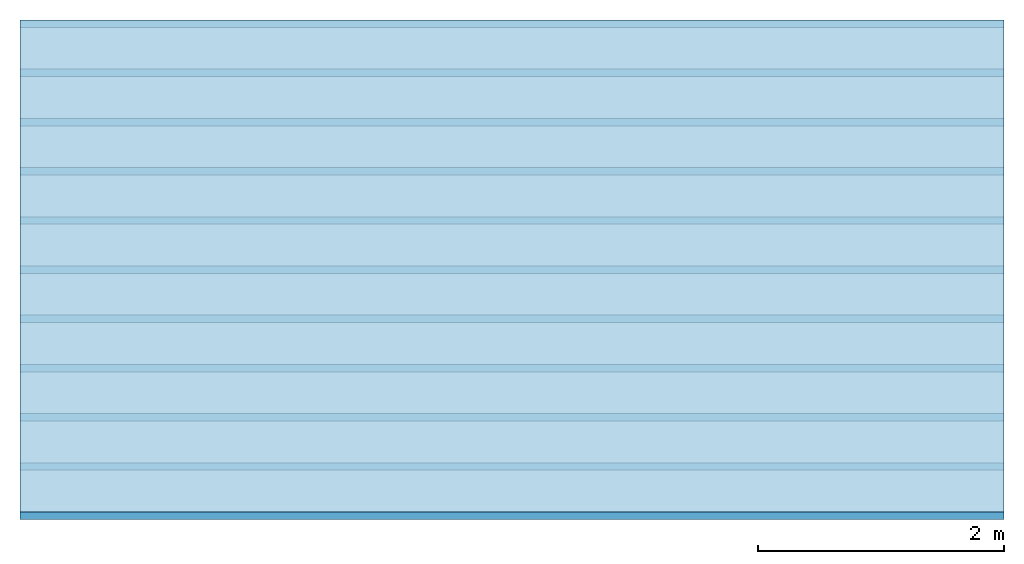
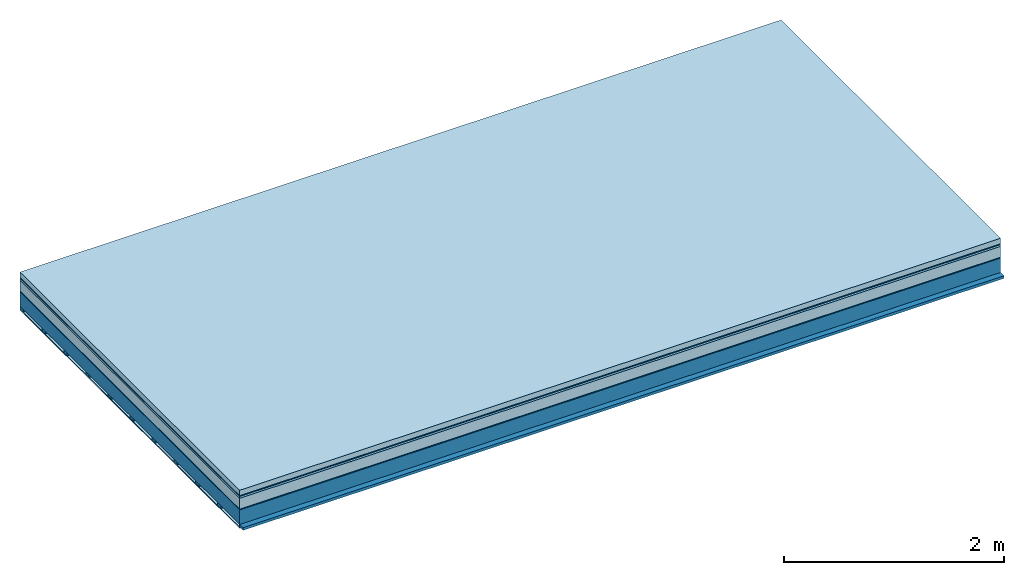
# One storey: 7 plates, 2 members, 1 element without a shape of its own.
"""IFC4 building model written with IfcOpenShell, lengths in metres."""

from ifc_helpers import new_model, si_unit, derived_unit, direction, frame, frame_2d, origin, origin_with_axes, place, context, project, spatial, rectangle, extrude, material, layer, layer_set, type_object, element, aggregate, save


model = new_model("IFC4")

# Units and contexts
plan_context = context("Plan", 3, precision=1e-05, world=origin(), true_north=direction((0.0, 1.0)))
model_context = context("Model", 3, precision=1e-05, world=origin(), true_north=direction((0.0, 1.0)))
ifc_project = project(units=[si_unit("LENGTHUNIT", "METRE"), derived_unit("SOUNDPRESSUREUNIT", [(si_unit("PRESSUREUNIT", "PASCAL", prefix="MICRO"), 0)]), si_unit("ENERGYUNIT", "JOULE", prefix="MEGA"), si_unit("MASSUNIT", "GRAM", prefix="KILO"), derived_unit("THERMALTRANSMITTANCEUNIT", [(si_unit("POWERUNIT", "WATT"), 1), (si_unit("AREAUNIT", "SQUARE_METRE"), -1), (si_unit("THERMODYNAMICTEMPERATUREUNIT", "KELVIN"), -1)]), derived_unit("AREADENSITYUNIT", [(si_unit("MASSUNIT", "GRAM", prefix="KILO"), 1), (si_unit("AREAUNIT", "SQUARE_METRE"), -1)]), derived_unit("USERDEFINED", [(si_unit("ENERGYUNIT", "JOULE", prefix="MEGA"), 1), (si_unit("AREAUNIT", "SQUARE_METRE"), -1)])], contexts=[plan_context, model_context])

# Site, building, storey
site = spatial("IfcSite", under=ifc_project)
building_placement = place(None, origin())
building = spatial("IfcBuilding", under=site, at=building_placement)
storey_placement = place(building_placement, origin())
storey = spatial("IfcBuildingStorey", under=building, at=storey_placement)

# Slab, members, plates
ifc_material_1 = material(Name="clay", Category="02.004")
ifc_layer_1 = layer(ifc_material_1, 0.06, Name="Use and protection layer 2")
ifc_material_2 = material(Name="Protective layer", Category="09.007")
ifc_layer_2 = layer(ifc_material_2, 0.01, Name="Use and protection layer 1")
ifc_material_3 = material(Name="Bituminous", Category="09.003")
ifc_layer_3 = layer(ifc_material_3, 0.02, Name="Seal")
ifc_material_4 = material(Name="Mineral wool", Category="10.008")
ifc_layer_4 = layer(ifc_material_4, 0.12, Name="Exterior insulation layer 1")
ifc_material_5 = material(Name="Vapor-permeable barrier", Category="09.006")
ifc_layer_5 = layer(ifc_material_5, 0.01, Name="layer / temporary roof")
ifc_material_6 = material(Name="no composite action")
ifc_layer_6 = layer(ifc_material_6, 0.0, Name="Bond")
ifc_layer_7 = layer(None, 0.16, Name="Support")
ifc_material_7 = material(Name="of the art")
ifc_layer_8 = layer(ifc_material_7, 0.0, Name="Bond")
ifc_layer_9 = layer(None, 0.03, Name="Battens / profiles")
ifc_material_8 = material(Name="Plasterboard type A", Category="03.008")
ifc_layer_10 = layer(ifc_material_8, 0.0125, Name="Covering below 1st layer")
ifc_material_9 = material(Category="04.001")
ifc_layer_11 = layer(ifc_material_9, 0.003, Name="Surface below")
ifc_layer_set = layer_set([ifc_layer_1, ifc_layer_2, ifc_layer_3, ifc_layer_4, ifc_layer_5, ifc_layer_6, ifc_layer_7, ifc_layer_8, ifc_layer_9, ifc_layer_10, ifc_layer_11])
slab_type = type_object("IfcSlabType", Name="F0073", PredefinedType="NOTDEFINED", material=ifc_layer_set)
slab_placement = place(None, frame((0.0, 0.0, 0.0), z_axis=(0.0, 0.0, -1.0), x_axis=(1.0, 0.0, 0.0)))
slab = element("IfcSlab", 1, at=slab_placement, inside=storey, type_object=slab_type, material=ifc_layer_set, Name="Slab #1")
ifc_material_10 = material(Name="Solid timber panel")
member_1_placement = place(slab_placement, origin())
member_1 = element("IfcMember", 2, at=member_1_placement, material=ifc_material_10, Name="Support", context=plan_context, shape_type="SweptSolid", body=[
    extrude(rectangle(XDim=1.0, YDim=0.16, at=frame_2d((0.5, 0.08), x_axis=(1.0, 0.0))), frame((0.0, 4.0, 0.22), z_axis=(0.0, -1.0, 0.0), x_axis=(1.0, 0.0, 0.0)), (0.0, 0.0, 1.0), 4.0),
    extrude(rectangle(XDim=1.0, YDim=0.16, at=frame_2d((0.5, 0.08), x_axis=(1.0, 0.0))), frame((1.0, 4.0, 0.22), z_axis=(0.0, -1.0, 0.0), x_axis=(1.0, 0.0, 0.0)), (0.0, 0.0, 1.0), 4.0),
    extrude(rectangle(XDim=1.0, YDim=0.16, at=frame_2d((0.5, 0.08), x_axis=(1.0, 0.0))), frame((2.0, 4.0, 0.22), z_axis=(0.0, -1.0, 0.0), x_axis=(1.0, 0.0, 0.0)), (0.0, 0.0, 1.0), 4.0),
    extrude(rectangle(XDim=1.0, YDim=0.16, at=frame_2d((0.5, 0.08), x_axis=(1.0, 0.0))), frame((3.0, 4.0, 0.22), z_axis=(0.0, -1.0, 0.0), x_axis=(1.0, 0.0, 0.0)), (0.0, 0.0, 1.0), 4.0),
    extrude(rectangle(XDim=1.0, YDim=0.16, at=frame_2d((0.5, 0.08), x_axis=(1.0, 0.0))), frame((4.0, 4.0, 0.22), z_axis=(0.0, -1.0, 0.0), x_axis=(1.0, 0.0, 0.0)), (0.0, 0.0, 1.0), 4.0),
    extrude(rectangle(XDim=1.0, YDim=0.16, at=frame_2d((0.5, 0.08), x_axis=(1.0, 0.0))), frame((5.0, 4.0, 0.22), z_axis=(0.0, -1.0, 0.0), x_axis=(1.0, 0.0, 0.0)), (0.0, 0.0, 1.0), 4.0),
    extrude(rectangle(XDim=1.0, YDim=0.16, at=frame_2d((0.5, 0.08), x_axis=(1.0, 0.0))), frame((6.0, 4.0, 0.22), z_axis=(0.0, -1.0, 0.0), x_axis=(1.0, 0.0, 0.0)), (0.0, 0.0, 1.0), 4.0),
    extrude(rectangle(XDim=1.0, YDim=0.16, at=frame_2d((0.5, 0.08), x_axis=(1.0, 0.0))), frame((7.0, 4.0, 0.22), z_axis=(0.0, -1.0, 0.0), x_axis=(1.0, 0.0, 0.0)), (0.0, 0.0, 1.0), 4.0),
])
ifc_material_11 = material()
member_2_placement = place(slab_placement, origin())
member_2 = element("IfcMember", 3, at=member_2_placement, material=ifc_material_11, Name="Battens / profiles", context=plan_context, shape_type="SweptSolid", body=[
    extrude(rectangle(XDim=0.06, YDim=0.03, at=frame_2d((0.03, 0.015), x_axis=(1.0, 0.0))), frame((0.0, 0.0, 0.38), z_axis=(1.0, 0.0, 0.0), x_axis=(0.0, 1.0, 0.0)), (0.0, 0.0, 1.0), 8.0),
    extrude(rectangle(XDim=0.06, YDim=0.03, at=frame_2d((0.03, 0.015), x_axis=(1.0, 0.0))), frame((0.0, 0.4, 0.38), z_axis=(1.0, 0.0, 0.0), x_axis=(0.0, 1.0, 0.0)), (0.0, 0.0, 1.0), 8.0),
    extrude(rectangle(XDim=0.06, YDim=0.03, at=frame_2d((0.03, 0.015), x_axis=(1.0, 0.0))), frame((0.0, 0.8, 0.38), z_axis=(1.0, 0.0, 0.0), x_axis=(0.0, 1.0, 0.0)), (0.0, 0.0, 1.0), 8.0),
    extrude(rectangle(XDim=0.06, YDim=0.03, at=frame_2d((0.03, 0.015), x_axis=(1.0, 0.0))), frame((0.0, 1.2, 0.38), z_axis=(1.0, 0.0, 0.0), x_axis=(0.0, 1.0, 0.0)), (0.0, 0.0, 1.0), 8.0),
    extrude(rectangle(XDim=0.06, YDim=0.03, at=frame_2d((0.03, 0.015), x_axis=(1.0, 0.0))), frame((0.0, 1.6, 0.38), z_axis=(1.0, 0.0, 0.0), x_axis=(0.0, 1.0, 0.0)), (0.0, 0.0, 1.0), 8.0),
    extrude(rectangle(XDim=0.06, YDim=0.03, at=frame_2d((0.03, 0.015), x_axis=(1.0, 0.0))), frame((0.0, 2.0, 0.38), z_axis=(1.0, 0.0, 0.0), x_axis=(0.0, 1.0, 0.0)), (0.0, 0.0, 1.0), 8.0),
    extrude(rectangle(XDim=0.06, YDim=0.03, at=frame_2d((0.03, 0.015), x_axis=(1.0, 0.0))), frame((0.0, 2.4, 0.38), z_axis=(1.0, 0.0, 0.0), x_axis=(0.0, 1.0, 0.0)), (0.0, 0.0, 1.0), 8.0),
    extrude(rectangle(XDim=0.06, YDim=0.03, at=frame_2d((0.03, 0.015), x_axis=(1.0, 0.0))), frame((0.0, 2.8, 0.38), z_axis=(1.0, 0.0, 0.0), x_axis=(0.0, 1.0, 0.0)), (0.0, 0.0, 1.0), 8.0),
    extrude(rectangle(XDim=0.06, YDim=0.03, at=frame_2d((0.03, 0.015), x_axis=(1.0, 0.0))), frame((0.0, 3.2, 0.38), z_axis=(1.0, 0.0, 0.0), x_axis=(0.0, 1.0, 0.0)), (0.0, 0.0, 1.0), 8.0),
    extrude(rectangle(XDim=0.06, YDim=0.03, at=frame_2d((0.03, 0.015), x_axis=(1.0, 0.0))), frame((0.0, 3.6, 0.38), z_axis=(1.0, 0.0, 0.0), x_axis=(0.0, 1.0, 0.0)), (0.0, 0.0, 1.0), 8.0),
    extrude(rectangle(XDim=0.06, YDim=0.03, at=frame_2d((0.03, 0.015), x_axis=(1.0, 0.0))), frame((0.0, 4.0, 0.38), z_axis=(1.0, 0.0, 0.0), x_axis=(0.0, 1.0, 0.0)), (0.0, 0.0, 1.0), 8.0),
])
plate_1_placement = place(slab_placement, origin())
plate_1 = element("IfcPlate", 4, at=plate_1_placement, material=ifc_material_1, Name="Use and protection layer 2", context=plan_context, shape_type="SweptSolid", body=[
    extrude(rectangle(XDim=8.0, YDim=4.0, at=frame_2d((4.0, 2.0), x_axis=(1.0, 0.0))), origin_with_axes(), (0.0, 0.0, 1.0), 0.06),
])
plate_2_placement = place(slab_placement, origin())
plate_2 = element("IfcPlate", 5, at=plate_2_placement, material=ifc_material_2, Name="Use and protection layer 1", context=plan_context, shape_type="SweptSolid", body=[
    extrude(rectangle(XDim=8.0, YDim=4.0, at=frame_2d((4.0, 2.0), x_axis=(1.0, 0.0))), frame((0.0, 0.0, 0.06), z_axis=(0.0, 0.0, 1.0), x_axis=(1.0, 0.0, 0.0)), (0.0, 0.0, 1.0), 0.01),
])
plate_3_placement = place(slab_placement, origin())
plate_3 = element("IfcPlate", 6, at=plate_3_placement, material=ifc_material_3, Name="Seal", context=plan_context, shape_type="SweptSolid", body=[
    extrude(rectangle(XDim=8.0, YDim=4.0, at=frame_2d((4.0, 2.0), x_axis=(1.0, 0.0))), frame((0.0, 0.0, 0.07), z_axis=(0.0, 0.0, 1.0), x_axis=(1.0, 0.0, 0.0)), (0.0, 0.0, 1.0), 0.02),
])
plate_4_placement = place(slab_placement, origin())
plate_4 = element("IfcPlate", 7, at=plate_4_placement, material=ifc_material_4, Name="Exterior insulation layer 1", context=plan_context, shape_type="SweptSolid", body=[
    extrude(rectangle(XDim=8.0, YDim=4.0, at=frame_2d((4.0, 2.0), x_axis=(1.0, 0.0))), frame((0.0, 0.0, 0.09), z_axis=(0.0, 0.0, 1.0), x_axis=(1.0, 0.0, 0.0)), (0.0, 0.0, 1.0), 0.12),
])
plate_5_placement = place(slab_placement, origin())
plate_5 = element("IfcPlate", 8, at=plate_5_placement, material=ifc_material_5, Name="layer / temporary roof", context=plan_context, shape_type="SweptSolid", body=[
    extrude(rectangle(XDim=8.0, YDim=4.0, at=frame_2d((4.0, 2.0), x_axis=(1.0, 0.0))), frame((0.0, 0.0, 0.21), z_axis=(0.0, 0.0, 1.0), x_axis=(1.0, 0.0, 0.0)), (0.0, 0.0, 1.0), 0.01),
])
plate_6_placement = place(slab_placement, origin())
plate_6 = element("IfcPlate", 9, at=plate_6_placement, material=ifc_material_8, Name="Covering below 1st layer", context=plan_context, shape_type="SweptSolid", body=[
    extrude(rectangle(XDim=8.0, YDim=4.0, at=frame_2d((4.0, 2.0), x_axis=(1.0, 0.0))), frame((0.0, 0.0, 0.41), z_axis=(0.0, 0.0, 1.0), x_axis=(1.0, 0.0, 0.0)), (0.0, 0.0, 1.0), 0.0125),
])
plate_7_placement = place(slab_placement, origin())
plate_7 = element("IfcPlate", 10, at=plate_7_placement, material=ifc_material_9, Name="Surface below", context=plan_context, shape_type="SweptSolid", body=[
    extrude(rectangle(XDim=8.0, YDim=4.0, at=frame_2d((4.0, 2.0), x_axis=(1.0, 0.0))), frame((0.0, 0.0, 0.4225), z_axis=(0.0, 0.0, 1.0), x_axis=(1.0, 0.0, 0.0)), (0.0, 0.0, 1.0), 0.003),
])
aggregate(slab, [plate_1, plate_2, plate_3, plate_4, plate_5, member_1, member_2, plate_6, plate_7])

save(model, "model.ifc")
